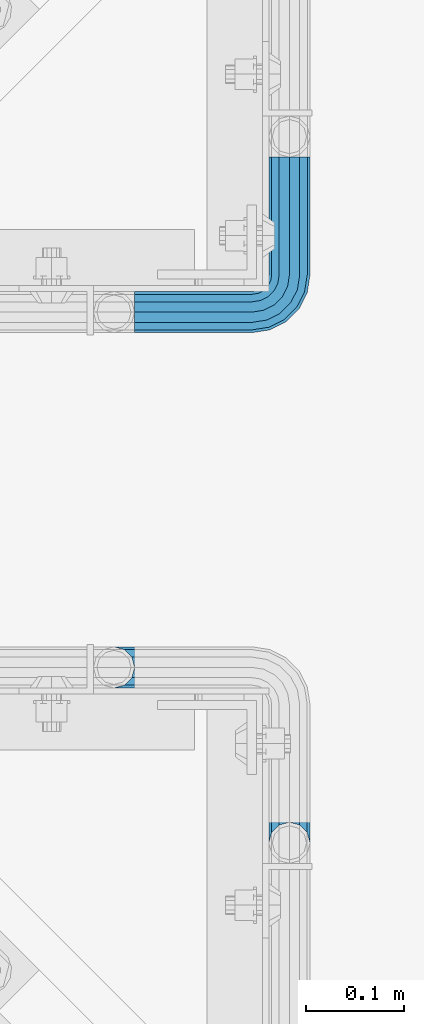
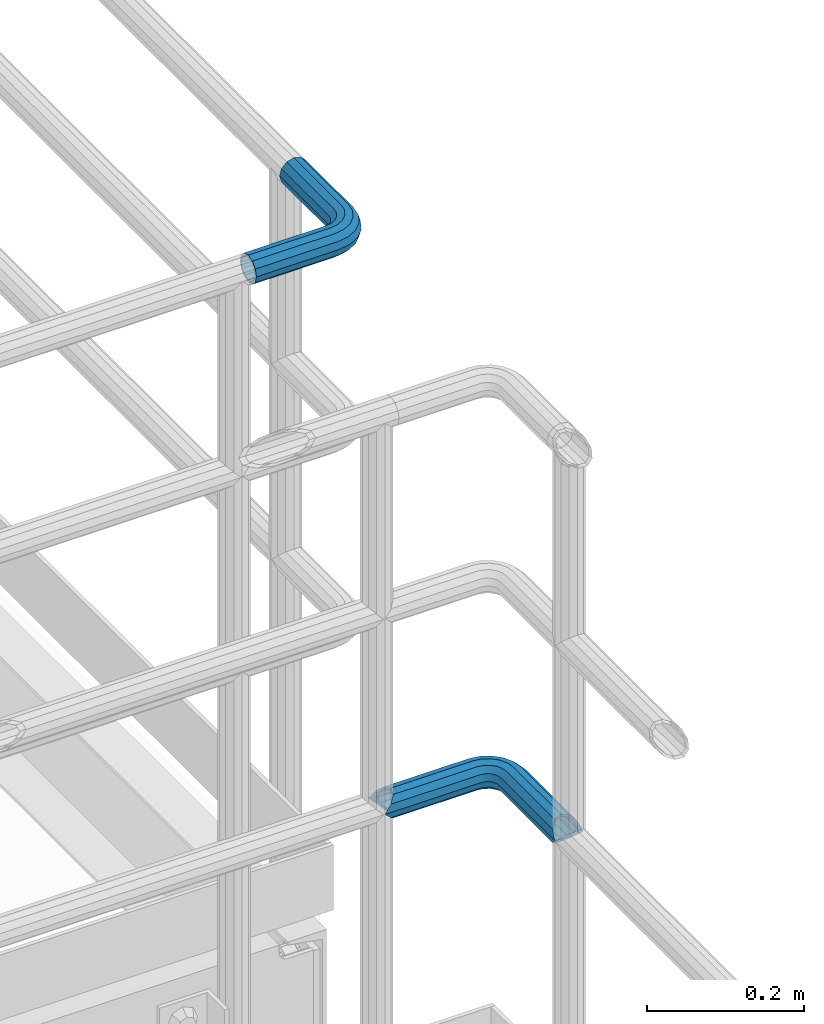
# One storey, part 1120 of 1876: 2 beams, 2 elements without a shape of their own.
"""IFC2X3 building model written with IfcOpenShell, lengths in millimetres."""

from ifc_helpers import new_model, si_unit, frame, origin_with_axes, place, context, subcontext, project, spatial, faceted_brep, material, type_object, element, aggregate, save


model = new_model("IFC2X3")

# Units and contexts
model_context = context("Model", 3, precision=1e-05, world=origin_with_axes())
body_context = subcontext(model_context, "Body", "Model", "MODEL_VIEW")
ifc_project = project(units=[si_unit("LENGTHUNIT", "METRE", prefix="MILLI"), si_unit("AREAUNIT", "SQUARE_METRE"), si_unit("VOLUMEUNIT", "CUBIC_METRE"), si_unit("MASSUNIT", "GRAM", prefix="KILO"), si_unit("TIMEUNIT", "SECOND"), si_unit("PLANEANGLEUNIT", "RADIAN"), si_unit("SOLIDANGLEUNIT", "STERADIAN"), si_unit("THERMODYNAMICTEMPERATUREUNIT", "DEGREE_CELSIUS"), si_unit("LUMINOUSINTENSITYUNIT", "LUMEN")], contexts=[model_context])

# Site, building, storey
site_placement = place(None, origin_with_axes())
site = spatial("IfcSite", under=ifc_project, at=site_placement, CompositionType="ELEMENT")
building_placement = place(site_placement, origin_with_axes())
building = spatial("IfcBuilding", under=site, at=building_placement, Name="Undefined", CompositionType="ELEMENT")
storey_placement = place(building_placement, origin_with_axes())
storey = spatial("IfcBuildingStorey", under=building, at=storey_placement, Name="Undefined", CompositionType="ELEMENT", Elevation=0.0)

# Assembly, beam
assembly_1_placement = place(storey_placement, origin_with_axes())
assembly_1 = element("IfcElementAssembly", 1, at=assembly_1_placement, inside=storey, Name="HANDRAIL", AssemblyPlace="NOTDEFINED", PredefinedType="RIGID_FRAME")
ifc_material = material()
beam_type = type_object("IfcBeamType", Name="PIPE1-1/4STD", PredefinedType="NOTDEFINED")
beam_1_placement = place(assembly_1_placement, frame((6866.33912093762, -11381.1963554687, 9090.025), z_axis=(0.0, 0.0, -1.0), x_axis=(1.0, 0.0, 0.0)))
beam_1 = element("IfcBeam", 2, at=beam_1_placement, type_object=beam_type, material=ifc_material, Name="HANDRAIL", ObjectType="PIPE1-1/4STD", context=body_context, shape_type="Brep", body=[
    faceted_brep([(9.09494701772928e-13, -21.0820000000003, 0.0), (0.0, -18.2575475625836, -10.5409999999993), (120.6947555542, -18.2575475625854, -10.5409999999956), (120.694755554199, -21.0820000000022, 3.63797880709171e-12), (0.0, -10.5410000000002, -18.2575475625836), (120.6947555542, -10.5410000000029, -18.2575475625799), (-4.28826751885936e-09, 0.0, -21.0820000000003), (120.694755554201, -3.63797880709171e-12, -21.0819999999967), (0.0, 10.5410000000002, -18.2575475625836), (120.694755554201, 10.5409999999974, -18.2575475625799), (0.0, 18.2575475625836, -10.5409999999993), (120.694755554201, 18.2575475625799, -10.5409999999956), (9.09494701772928e-13, 21.0820000000003, 0.0), (120.694755554201, 21.0819999999967, 3.63797880709171e-12), (0.0, 18.2575475625836, 10.5409999999993), (120.6947555542, 18.2575475625799, 10.5410000000047), (0.0, 10.5410000000002, 18.2575475625836), (120.6947555542, 10.5409999999974, 18.2575475625872), (0.0, 0.0, 21.0820000000003), (120.694755554199, -3.63797880709171e-12, 21.082000000004), (0.0, -10.5410000000002, 18.2575475625836), (120.694755554199, -10.5410000000029, 18.2575475625872), (0.0, -18.2575475625836, 10.5409999999993), (120.694755554199, -18.2575475625872, 10.5410000000047), (0.0, -17.5259999999998, 0.0), (0.0, -15.1779612267264, 8.76300000000083), (120.694755554199, -15.1779612267292, 8.76300000000447), (120.6947555542, -17.5260000000035, 3.63797880709171e-12), (0.0, -8.76299999999992, 15.1779612267255), (120.694755554199, -8.76300000000265, 15.177961226731), (0.0, 0.0, 17.5259999999998), (120.694755554199, -3.63797880709171e-12, 17.5260000000035), (0.0, 8.76299999999992, 15.1779612267255), (120.6947555542, 8.76299999999719, 15.177961226731), (0.0, 15.1779612267264, 8.76300000000083), (120.6947555542, 15.1779612267237, 8.76300000000447), (0.0, 17.5259999999998, 0.0), (120.694755554201, 17.525999999998, 3.63797880709171e-12), (0.0, 15.1779612267264, -8.76300000000083), (120.694755554201, 15.1779612267237, -8.76299999999537), (0.0, 8.76299999999992, -15.1779612267255), (120.694755554201, 8.76299999999719, -15.1779612267219), (0.0, 0.0, -17.5259999999998), (120.694755554201, -3.63797880709171e-12, -17.5259999999962), (0.0, -8.76299999999992, -15.1779612267255), (120.6947555542, -8.76300000000265, -15.1779612267219), (0.0, -15.1779612267264, -8.76300000000083), (120.6947555542, -15.1779612267292, -8.76299999999537), (125.95360629295, -21.9149201310101, 3.63797880709171e-12), (126.826410095915, -19.2287062354389, 10.5410000000047), (129.210954430656, -11.8898333927427, 18.2575475625872), (132.468302568363, -1.86474665447531, 21.082000000004), (135.725650706068, 8.16034008379211, 18.257547562589), (138.11019504081, 15.4992129264883, 10.5410000000047), (138.982998843776, 18.1854268220577, 5.45696821063757e-12), (138.110195040815, 15.4992129264865, -10.5409999999956), (135.72565070607, 8.16034008379211, -18.2575475625781), (132.468302568363, -1.86474665447531, -21.0819999999949), (129.210954430657, -11.8898333927427, -18.2575475625799), (126.826410095916, -19.2287062354389, -10.5409999999956), (137.884134411778, 14.8034698501124, 5.45696821063757e-12), (137.158550527389, 12.5703522742751, 8.76300000000447), (135.17621849007, 6.46936159781944, 15.177961226731), (132.468302568363, -1.86474665447531, 17.5260000000053), (129.760386646654, -10.1988549067701, 15.177961226731), (127.77805460934, -16.2998455832294, 8.76300000000447), (127.052470724947, -18.5329631590648, 3.63797880709171e-12), (127.77805460934, -16.2998455832294, -8.76299999999537), (129.760386646655, -10.1988549067701, -15.1779612267219), (132.468302568363, -1.86474665447531, -17.5259999999962), (135.176218490071, 6.46936159781762, -15.1779612267219), (137.158550527385, 12.570352274277, -8.76299999999537), (149.285217114073, 1.25139591480183, 18.257547562589), (153.820889969974, 7.49421403083397, 10.5410000000047), (143.089372769657, -7.27645222290448, 21.082000000004), (136.893528425241, -15.804300360609, 18.2575475625872), (132.35785556934, -22.0471184766411, 10.5410000000047), (130.697684080826, -24.3321484983135, 3.63797880709171e-12), (132.357855569341, -22.0471184766411, -10.5409999999956), (136.893528425242, -15.804300360609, -18.2575475625781), (143.089372769658, -7.27645222290266, -21.0819999999949), (149.285217114074, 1.25139591480183, -18.2575475625781), (153.820889969975, 7.49421403083397, -10.5409999999956), (155.481061458489, 9.77924405250815, 5.45696821063757e-12), (152.010754538596, 5.00277634947997, -8.76299999999537), (153.390897101337, 6.90237962051106, 5.45696821063757e-12), (148.240134935498, -0.187036301196713, -15.1779612267219), (143.089372769658, -7.27645222290266, -17.5259999999944), (137.938610603818, -14.3658681446104, -15.1779612267219), (134.16799100072, -19.5556807952871, -8.76299999999537), (132.787848437978, -21.4552840663182, 3.63797880709171e-12), (134.167991000719, -19.5556807952871, 8.76300000000447), (137.938610603817, -14.3658681446104, 15.177961226731), (143.089372769657, -7.27645222290448, 17.5260000000053), (148.240134935497, -0.187036301196713, 15.177961226731), (152.010754538595, 5.00277634947997, 8.76300000000447), (160.046149943129, -9.50953691425639, 18.257547562589), (166.288968059162, -4.97386405835641, 10.5410000000047), (151.518301805423, -15.705381258671, 21.082000000004), (142.990453667717, -21.9012256030855, 18.257547562589), (136.747635551684, -26.4368984589855, 10.5410000000047), (134.46260553001, -28.0970699475001, 3.63797880709171e-12), (136.747635551685, -26.4368984589855, -10.5409999999956), (142.990453667717, -21.9012256030855, -18.2575475625781), (151.518301805424, -15.705381258671, -21.0819999999949), (160.04614994313, -9.50953691425639, -18.2575475625781), (166.28896805916, -4.97386405835277, -10.5409999999956), (168.573998080837, -3.31369256984181, 5.45696821063757e-12), (163.797530377809, -6.78399948973492, -8.76299999999537), (165.697133648839, -5.40385692699419, 5.45696821063757e-12), (158.607717727132, -10.5546190928326, -15.1779612267219), (151.518301805424, -15.705381258671, -17.5259999999944), (144.428885883715, -20.8561434245094, -15.1779612267219), (139.239073233038, -24.626763027607, -8.76299999999537), (137.339469962008, -26.0069055903477, 3.63797880709171e-12), (139.239073233038, -24.626763027607, 8.76300000000447), (144.428885883715, -20.8561434245094, 15.177961226731), (151.518301805423, -15.705381258671, 17.5260000000053), (158.607717727131, -10.5546190928326, 15.177961226731), (163.797530377807, -6.78399948973129, 8.76300000000447), (166.955094112112, -23.069103322252, 18.257547562589), (174.29396695481, -20.6845589875102, 10.5410000000047), (156.930007373846, -26.3264514599596, 21.082000000004), (146.904920635579, -29.5837995976653, 18.2575475625872), (139.566047792883, -31.9683439324072, 10.5410000000047), (136.879833897313, -32.8411477353729, 3.63797880709171e-12), (139.566047792883, -31.9683439324072, -10.5409999999956), (146.904920635579, -29.5837995976653, -18.2575475625781), (156.930007373847, -26.3264514599578, -21.0819999999949), (166.955094112113, -23.0691033222502, -18.2575475625781), (174.29396695481, -20.6845589875102, -10.5409999999956), (176.98018085038, -19.8117551845444, 5.45696821063757e-12), (171.365106302599, -21.6362035009352, -8.76299999999537), (173.598223878435, -20.9106196165412, 5.45696821063757e-12), (165.264115626141, -23.6185355382495, -15.1779612267219), (156.930007373847, -26.3264514599578, -17.5259999999944), (148.595899121552, -29.034367381666, -15.1779612267219), (142.494908445094, -31.0166994189822, -8.76299999999537), (140.261790869258, -31.7422833033743, 3.63797880709171e-12), (142.494908445094, -31.0166994189822, 8.76300000000447), (148.595899121552, -29.034367381666, 15.177961226731), (156.930007373846, -26.3264514599578, 17.5260000000053), (165.264115626141, -23.6185355382495, 15.177961226731), (171.365106302599, -21.6362035009352, 8.76300000000447), (148.25375402832, -38.0999984741229, -18.2575475625799), (140.537206465737, -38.0999984741229, -10.5409999999956), (158.79475402832, -38.0999984741229, -21.0819999999949), (169.33575402832, -38.0999984741229, -18.2575475625781), (177.052301590904, -38.0999984741247, -10.5409999999956), (179.87675402832, -38.0999984741247, 5.45696821063757e-12), (177.052301590903, -38.0999984741247, 10.5410000000047), (169.33575402832, -38.0999984741247, 18.257547562589), (158.794754028319, -38.0999984741247, 21.082000000004), (148.253754028319, -38.0999984741247, 18.2575475625872), (140.537206465737, -38.0999984741247, 10.5410000000047), (137.71275402832, -38.0999984741247, 5.45696821063757e-12), (173.972715255046, -38.0999984741247, -8.76299999999537), (176.32075402832, -38.0999984741247, 5.45696821063757e-12), (167.55775402832, -38.0999984741229, -15.1779612267219), (158.79475402832, -38.0999984741229, -17.5259999999962), (150.03175402832, -38.0999984741229, -15.1779612267219), (143.616792801594, -38.0999984741229, -8.76299999999537), (141.26875402832, -38.0999984741247, 5.45696821063757e-12), (143.616792801594, -38.0999984741247, 8.76300000000447), (150.031754028319, -38.0999984741247, 15.177961226731), (158.794754028319, -38.0999984741247, 17.5260000000053), (167.557754028319, -38.0999984741247, 15.177961226731), (173.972715255046, -38.0999984741247, 8.76300000000447), (140.537206465737, -158.797622680664, -10.5409999999974), (137.71275402832, -158.797622680664, 1.81898940354586e-12), (148.25375402832, -158.797622680664, -18.2575475625817), (158.79475402832, -158.797622680664, -21.0819999999985), (169.33575402832, -158.797622680664, -18.2575475625817), (177.052301590904, -158.797622680664, -10.5409999999974), (179.876754028321, -158.797622680664, 1.81898940354586e-12), (177.052301590904, -158.797622680664, 10.5410000000011), (169.33575402832, -158.797622680664, 18.2575475625854), (158.79475402832, -158.797622680664, 21.0820000000022), (148.25375402832, -158.797622680664, 18.2575475625854), (140.537206465737, -158.797622680664, 10.5410000000011), (143.616792801594, -158.797622680664, 8.76300000000265), (141.26875402832, -158.797622680664, 1.81898940354586e-12), (150.03175402832, -158.797622680664, 15.1779612267273), (158.79475402832, -158.797622680664, 17.5260000000017), (167.55775402832, -158.797622680664, 15.1779612267273), (173.972715255047, -158.797622680664, 8.76300000000265), (176.32075402832, -158.797622680664, 1.81898940354586e-12), (173.972715255047, -158.797622680664, -8.76299999999901), (167.55775402832, -158.797622680664, -15.1779612267237), (158.79475402832, -158.797622680664, -17.525999999998), (150.03175402832, -158.797622680664, -15.1779612267237), (143.616792801594, -158.797622680664, -8.76299999999901)], [[[0, 1, 2, 3]], [[1, 4, 5, 2]], [[4, 6, 7, 5]], [[6, 8, 9, 7]], [[8, 10, 11, 9]], [[10, 12, 13, 11]], [[12, 14, 15, 13]], [[14, 16, 17, 15]], [[16, 18, 19, 17]], [[18, 20, 21, 19]], [[20, 22, 23, 21]], [[22, 0, 3, 23]], [[24, 25, 26, 27]], [[25, 28, 29, 26]], [[28, 30, 31, 29]], [[30, 32, 33, 31]], [[32, 34, 35, 33]], [[34, 36, 37, 35]], [[36, 38, 39, 37]], [[38, 40, 41, 39]], [[40, 42, 43, 41]], [[42, 44, 45, 43]], [[44, 46, 47, 45]], [[46, 24, 27, 47]], [[22, 20, 18, 16, 14, 12, 10, 8, 6, 4, 1, 0], [46, 44, 42, 40, 38, 36, 34, 32, 30, 28, 25, 24]], [[23, 3, 48, 49]], [[21, 23, 49, 50]], [[19, 21, 50, 51]], [[17, 19, 51, 52]], [[15, 17, 52, 53]], [[13, 15, 53, 54]], [[11, 13, 54, 55]], [[9, 11, 55, 56]], [[7, 9, 56, 57]], [[5, 7, 57, 58]], [[2, 5, 58, 59]], [[3, 2, 59, 48]], [[35, 37, 60, 61]], [[33, 35, 61, 62]], [[31, 33, 62, 63]], [[29, 31, 63, 64]], [[26, 29, 64, 65]], [[27, 26, 65, 66]], [[47, 27, 66, 67]], [[45, 47, 67, 68]], [[43, 45, 68, 69]], [[41, 43, 69, 70]], [[39, 41, 70, 71]], [[37, 39, 71, 60]], [[52, 72, 73, 53]], [[51, 74, 72, 52]], [[50, 75, 74, 51]], [[49, 76, 75, 50]], [[48, 77, 76, 49]], [[59, 78, 77, 48]], [[58, 79, 78, 59]], [[57, 80, 79, 58]], [[56, 81, 80, 57]], [[55, 82, 81, 56]], [[54, 83, 82, 55]], [[53, 73, 83, 54]], [[71, 84, 85, 60]], [[70, 86, 84, 71]], [[69, 87, 86, 70]], [[68, 88, 87, 69]], [[67, 89, 88, 68]], [[66, 90, 89, 67]], [[65, 91, 90, 66]], [[64, 92, 91, 65]], [[63, 93, 92, 64]], [[62, 94, 93, 63]], [[61, 95, 94, 62]], [[60, 85, 95, 61]], [[72, 96, 97, 73]], [[74, 98, 96, 72]], [[75, 99, 98, 74]], [[76, 100, 99, 75]], [[77, 101, 100, 76]], [[78, 102, 101, 77]], [[79, 103, 102, 78]], [[80, 104, 103, 79]], [[81, 105, 104, 80]], [[82, 106, 105, 81]], [[83, 107, 106, 82]], [[73, 97, 107, 83]], [[84, 108, 109, 85]], [[86, 110, 108, 84]], [[87, 111, 110, 86]], [[88, 112, 111, 87]], [[89, 113, 112, 88]], [[90, 114, 113, 89]], [[91, 115, 114, 90]], [[92, 116, 115, 91]], [[93, 117, 116, 92]], [[94, 118, 117, 93]], [[95, 119, 118, 94]], [[85, 109, 119, 95]], [[96, 120, 121, 97]], [[98, 122, 120, 96]], [[99, 123, 122, 98]], [[100, 124, 123, 99]], [[101, 125, 124, 100]], [[102, 126, 125, 101]], [[103, 127, 126, 102]], [[104, 128, 127, 103]], [[105, 129, 128, 104]], [[106, 130, 129, 105]], [[107, 131, 130, 106]], [[97, 121, 131, 107]], [[108, 132, 133, 109]], [[110, 134, 132, 108]], [[111, 135, 134, 110]], [[112, 136, 135, 111]], [[113, 137, 136, 112]], [[114, 138, 137, 113]], [[115, 139, 138, 114]], [[116, 140, 139, 115]], [[117, 141, 140, 116]], [[118, 142, 141, 117]], [[119, 143, 142, 118]], [[109, 133, 143, 119]], [[127, 144, 145, 126]], [[128, 146, 144, 127]], [[129, 147, 146, 128]], [[130, 148, 147, 129]], [[131, 149, 148, 130]], [[121, 150, 149, 131]], [[120, 151, 150, 121]], [[122, 152, 151, 120]], [[123, 153, 152, 122]], [[124, 154, 153, 123]], [[125, 155, 154, 124]], [[126, 145, 155, 125]], [[132, 156, 157, 133]], [[134, 158, 156, 132]], [[135, 159, 158, 134]], [[136, 160, 159, 135]], [[137, 161, 160, 136]], [[138, 162, 161, 137]], [[139, 163, 162, 138]], [[140, 164, 163, 139]], [[141, 165, 164, 140]], [[142, 166, 165, 141]], [[143, 167, 166, 142]], [[133, 157, 167, 143]], [[155, 145, 168, 169]], [[145, 144, 170, 168]], [[144, 146, 171, 170]], [[146, 147, 172, 171]], [[147, 148, 173, 172]], [[148, 149, 174, 173]], [[149, 150, 175, 174]], [[150, 151, 176, 175]], [[151, 152, 177, 176]], [[152, 153, 178, 177]], [[153, 154, 179, 178]], [[154, 155, 169, 179]], [[162, 163, 180, 181]], [[163, 164, 182, 180]], [[164, 165, 183, 182]], [[165, 166, 184, 183]], [[166, 167, 185, 184]], [[167, 157, 186, 185]], [[157, 156, 187, 186]], [[156, 158, 188, 187]], [[158, 159, 189, 188]], [[159, 160, 190, 189]], [[160, 161, 191, 190]], [[161, 162, 181, 191]], [[170, 171, 172, 173, 174, 175, 176, 177, 178, 179, 169, 168], [182, 183, 184, 185, 186, 187, 188, 189, 190, 191, 181, 180]]]),
])
aggregate(assembly_1, [beam_1])

assembly_2_placement = place(storey_placement, origin_with_axes())
assembly_2 = element("IfcElementAssembly", 3, at=assembly_2_placement, inside=storey, Name="HANDRAIL", AssemblyPlace="NOTDEFINED", PredefinedType="RIGID_FRAME")
beam_2_placement = place(assembly_2_placement, frame((6845.30143150122, -11745.4324531237, 8480.425), z_axis=(0.0, 0.0, -1.0), x_axis=(1.0, 0.0, 0.0)))
beam_2 = element("IfcBeam", 4, at=beam_2_placement, type_object=beam_type, material=ifc_material, Name="HANDRAIL", ObjectType="PIPE1-1/4STD", context=body_context, shape_type="Brep", body=[
    faceted_brep([(9.09494701772928e-13, 21.0820000000003, 0.0), (10.5409999957128, 18.2575475579433, -10.5409999999993), (10.5409999999983, 18.2575475625836, 10.5410000000011), (10.5409999999983, -18.2575475625836, 10.5410000000011), (10.5409999957128, -18.2575475672238, -10.5409999999993), (9.09494701772928e-13, -21.0820000000003, 0.0), (18.2575475625817, -10.5410000000011, 18.2575475625836), (18.2575475625817, -10.5409999999974, 13.3999612267289), (13.6205863358537, -15.1779612267255, 8.76300000000083), (11.2725475625793, -17.5259999999998, 0.0), (13.6205863358537, -15.1779612267255, -8.76299999999901), (18.2575475625817, -10.5409999999974, -13.3999612267271), (18.2575475625817, -10.5410000000011, -18.2575475625836), (21.0819999999985, 0.0, -17.5259999999998), (21.0819999999985, 0.0, -21.0819999999985), (18.7339612267233, -8.76300000000083, -15.1779612267255), (18.7339612267251, 8.76299999999901, -15.1779612267255), (18.2575475625817, 10.5410000000011, -13.3999612267235), (18.2575475625817, 10.5409999999993, -18.2575475625836), (13.6205863358573, 15.1779612267255, -8.76299999999901), (11.2725475625839, 17.5259999999998, 0.0), (13.6205863358573, 15.1779612267255, 8.76300000000083), (18.2575475625817, 10.5410000000011, 13.3999612267253), (18.2575475625817, 10.5409999999993, 18.2575475625836), (18.7339612267251, 8.76299999999901, 15.1779612267273), (21.0819999999985, 1.81898940354586e-12, 17.5259999999998), (21.0819999999985, 1.81898940354586e-12, 21.0820000000003), (18.7339612267233, -8.76300000000083, 15.1779612267273), (141.729133605958, -8.76300000000265, 15.177961226731), (141.729133605958, -3.63797880709171e-12, 17.5260000000035), (153.502680620123, 1.86474665447895, 17.5259999999998), (156.210596541831, -6.46936159781399, 15.1779612267255), (141.729133605958, -15.1779612267292, 8.76300000000447), (158.192928579147, -12.5703522742733, 8.76300000000083), (141.729133605958, -17.5260000000035, 3.63797880709171e-12), (158.91851246354, -14.8034698501087, 0.0), (141.729133605959, -15.1779612267292, -8.76299999999537), (158.192928579147, -12.5703522742733, -8.76300000000083), (141.729133605959, -8.76300000000265, -15.1779612267219), (156.210596541831, -6.46936159781399, -15.1779612267255), (141.729133605959, -3.63797880709171e-12, -17.5259999999962), (153.502680620123, 1.86474665447895, -17.5259999999998), (141.72913360596, 8.76299999999719, -15.1779612267219), (150.794764698415, 10.1988549067737, -15.1779612267255), (141.72913360596, 15.1779612267237, -8.76299999999537), (148.8124326611, 16.2998455832312, -8.76300000000083), (141.729133605959, 17.525999999998, 3.63797880709171e-12), (148.086848776707, 18.5329631590685, 0.0), (141.729133605959, 15.1779612267237, 8.76300000000447), (148.8124326611, 16.2998455832312, 8.76300000000083), (141.729133605959, 8.76299999999719, 15.177961226731), (150.794764698415, 10.1988549067737, 15.1779612267255), (171.066132080078, 38.0999984741266, -15.1779612267255), (179.829132080078, 38.0999984741266, -17.5259999999998), (179.829132080079, 158.749951173106, -17.5259999999998), (171.066132080079, 161.097991264016, -15.1779612267255), (198.086679642661, 38.0999984741266, -10.5409999999993), (190.370132080077, 38.0999984741266, -18.2575475625836), (190.370132080079, 161.574403610522, -18.2575475625836), (198.086679642663, 169.290951173107, -10.5409999999993), (200.911132080079, 38.0999984741266, 0.0), (200.911136997563, 179.831951173106, 0.0), (198.086679642663, 169.290951173107, 10.5409999999993), (198.086679642661, 38.0999984741266, 10.5409999999993), (190.370132080077, 38.0999984741266, 18.2575475625836), (190.370132080079, 161.574403610522, 18.2575475625836), (179.829132080078, 38.0999984741266, 21.0820000000003), (179.829132080079, 158.749951173106, 21.0820000000003), (141.729133605959, 18.2575475625799, 10.5410000000047), (141.729133605959, 21.0819999999967, 3.63797880709171e-12), (141.72913360596, 18.2575475625799, -10.5409999999956), (141.72913360596, 10.5409999999974, -18.2575475625799), (141.729133605959, -3.63797880709171e-12, -21.0819999999949), (141.729133605959, -10.5410000000029, -18.2575475625799), (141.729133605959, -18.2575475625872, -10.5409999999956), (141.729133605958, -21.0820000000022, 3.63797880709171e-12), (141.729133605958, -18.2575475625872, 10.5410000000047), (141.729133605958, -10.5410000000029, 18.2575475625872), (141.729133605958, -3.63797880709171e-12, 21.082000000004), (141.729133605959, 10.5409999999974, 18.2575475625872), (150.245332482416, 11.8898333927464, 18.2575475625836), (147.860788147675, 19.2287062354426, 10.5409999999993), (146.987984344709, 21.9149201310138, 0.0), (147.860788147675, 19.2287062354426, -10.5409999999993), (150.245332482416, 11.8898333927464, -18.2575475625836), (153.502680620123, 1.86474665447895, -21.0820000000003), (156.760028757831, -8.16034008378665, -18.2575475625836), (159.144573092572, -15.4992129264829, -10.5409999999993), (160.017376895537, -18.1854268220541, 0.0), (159.144573092572, -15.4992129264829, 10.5409999999993), (156.760028757831, -8.16034008378665, 18.2575475625836), (153.502680620123, 1.86474665447895, 21.0820000000003), (164.123750821417, 7.27645222290812, 21.0820000000003), (157.927906477001, 15.8043003606126, 18.2575475625836), (170.319595165834, -1.25139591479638, 18.2575475625836), (174.855268021735, -7.49421403082852, 10.5409999999993), (176.51543951025, -9.77924405250269, 0.0), (174.855268021735, -7.49421403082852, -10.5409999999993), (170.319595165834, -1.25139591479638, -18.2575475625836), (164.123750821417, 7.27645222290812, -21.0820000000003), (157.927906477001, 15.8043003606126, -18.2575475625836), (153.3922336211, 22.0471184766448, -10.5409999999993), (151.732062132584, 24.3321484983171, 0.0), (153.3922336211, 22.0471184766448, 10.5409999999993), (164.024831719472, 21.9012256030837, 18.2575475625836), (157.782013603441, 26.4368984589855, 10.5409999999993), (172.552679857177, 15.7053812586691, 21.0820000000003), (181.080527994883, 9.50953691425275, 18.2575475625836), (187.323346110915, 4.97386405835096, 10.5409999999993), (189.608376132588, 3.31369256983635, 0.0), (187.323346110915, 4.97386405835096, -10.5409999999993), (181.080527994883, 9.50953691425275, -18.2575475625836), (172.552679857177, 15.7053812586691, -21.0820000000003), (164.024831719472, 21.9012256030837, -18.2575475625836), (157.782013603441, 26.4368984589855, -10.5409999999993), (155.496983581766, 28.0970699475001, 0.0), (160.600425844642, 31.9683439324108, 10.5409999999993), (157.914211949071, 32.8411477353766, 0.0), (167.939298687338, 29.583799597669, 18.2575475625836), (177.964385425605, 26.3264514599632, 21.0820000000003), (187.989472163872, 23.0691033222574, 18.2575475625836), (195.328345006568, 20.6845589875156, 10.5409999999993), (198.014558902139, 19.8117551845498, 0.0), (195.328345006568, 20.6845589875156, -10.5409999999993), (187.989472163872, 23.0691033222574, -18.2575475625836), (177.964385425605, 26.3264514599632, -21.0820000000003), (167.939298687338, 29.583799597669, -18.2575475625836), (160.600425844642, 31.9683439324108, -10.5409999999993), (158.747132080079, 38.0999984741266, 0.0), (161.571584517495, 38.0999984741266, -10.5409999999993), (161.571584517495, 38.0999984741266, 10.5409999999993), (169.288132080078, 38.0999984741266, 18.2575475625836), (179.829132080078, 38.0999984741266, -21.0820000000003), (169.288132080078, 38.0999984741266, -18.2575475625836), (161.571584517495, 169.290951173107, -10.5409999999993), (169.288132080079, 161.574403610522, -18.2575475625836), (179.829132080079, 158.749951173106, -21.0820000000003), (190.370136997562, 161.574403610522, -13.399956309242), (188.592132080079, 161.097988628744, -15.1779612267255), (188.592132080077, 38.0999984741266, -15.1779612267255), (195.007093306804, 38.0999984741266, -8.76300000000083), (195.007093306805, 166.211359919766, -8.76300000000083), (197.355132080079, 38.0999984741266, 0.0), (197.355132080079, 168.55939869304, 0.0), (195.007093306804, 38.0999984741266, 8.76300000000083), (195.007093306805, 166.211359919766, 8.76300000000083), (190.370136997562, 161.574403610522, 13.399956309242), (188.592132080077, 38.0999984741266, 15.1779612267255), (188.592132080079, 161.097988628744, 15.1779612267255), (179.829132080079, 158.749951173106, 17.5259999999998), (179.829132080078, 38.0999984741266, 17.5259999999998), (171.066132080078, 38.0999984741266, 15.1779612267255), (171.066132080079, 161.097991264016, 15.1779612267255), (162.303132080078, 38.0999984741266, 0.0), (164.651170853352, 38.0999984741266, -8.76300000000083), (164.651170853353, 166.211369754732, -8.76300000000083), (162.303132080079, 168.559408528006, 0.0), (164.651170853352, 38.0999984741266, 8.76300000000083), (164.651170853353, 166.211369754732, 8.76300000000083), (169.288136997562, 161.574403610522, 13.3999661442085), (169.288132080079, 161.574403610522, 18.2575475625836), (161.571584517495, 169.290951173107, 10.5409999999993), (158.747132080079, 179.831954956055, 0.0), (169.288136997562, 161.574403610522, -13.3999661442085), (169.630277173311, 29.0343673816715, -15.1779612267255), (163.529286496852, 31.0166994189858, -8.76300000000083), (177.964385425605, 26.3264514599632, -17.5259999999998), (186.298493677899, 23.6185355382549, -15.1779612267255), (192.399484354358, 21.6362035009406, -8.76300000000083), (194.632601930193, 20.9106196165467, 0.0), (192.399484354358, 21.6362035009406, 8.76300000000083), (186.298493677899, 23.6185355382549, 15.1779612267255), (177.964385425605, 26.3264514599632, 17.5259999999998), (169.630277173311, 29.0343673816715, 15.1779612267255), (163.529286496852, 31.0166994189858, 8.76300000000083), (161.296168921016, 31.7422833033779, 0.0), (160.273451284794, 24.626763027607, -8.76300000000083), (158.373848013764, 26.0069055903477, 0.0), (165.46326393547, 20.8561434245075, -15.1779612267255), (172.552679857177, 15.7053812586691, -17.5259999999998), (179.642095778884, 10.5546190928289, -15.1779612267255), (184.831908429562, 6.78399948973129, -8.76300000000083), (186.731511700591, 5.40385692698874, 0.0), (184.831908429562, 6.78399948973129, 8.76300000000083), (179.642095778884, 10.5546190928289, 15.1779612267255), (172.552679857177, 15.7053812586691, 17.5259999999998), (165.46326393547, 20.8561434245075, 15.1779612267255), (160.273451284794, 24.626763027607, 8.76300000000083), (153.822226489737, 21.45528406632, 0.0), (155.202369052478, 19.5556807952908, 8.76300000000083), (155.202369052478, 19.5556807952908, -8.76300000000083), (158.972988655577, 14.3658681446141, -15.1779612267255), (164.123750821417, 7.27645222290812, -17.5259999999998), (169.274512987257, 0.187036301200351, -15.1779612267255), (173.045132590356, -5.00277634947633, -8.76300000000083), (174.425275153098, -6.9023796205056, 0.0), (173.045132590356, -5.00277634947633, 8.76300000000083), (169.274512987257, 0.18703630120217, 15.1779612267255), (164.123750821417, 7.27645222290812, 17.5259999999998), (158.972988655577, 14.3658681446141, 15.1779612267255)], [[[0, 1, 2]], [[3, 4, 5]], [[6, 7, 8, 9, 10, 11, 12, 4, 3]], [[13, 14, 12, 11, 15]], [[16, 17, 18, 14, 13]], [[2, 1, 18, 17, 19, 20, 21, 22, 23]], [[23, 22, 24, 25, 26]], [[26, 25, 27, 7, 6]], [[28, 29, 30, 31]], [[32, 28, 31, 33]], [[34, 32, 33, 35]], [[36, 34, 35, 37]], [[38, 36, 37, 39]], [[40, 38, 39, 41]], [[42, 40, 41, 43]], [[44, 42, 43, 45]], [[46, 44, 45, 47]], [[48, 46, 47, 49]], [[50, 48, 49, 51]], [[52, 53, 54, 55]], [[56, 57, 58, 59]], [[60, 56, 59, 61]], [[61, 59, 62]], [[63, 60, 61, 62]], [[64, 63, 62, 65]], [[66, 64, 65, 67]], [[68, 69, 0, 2]], [[69, 70, 1, 0]], [[70, 71, 18, 1]], [[71, 72, 14, 18]], [[72, 73, 12, 14]], [[73, 74, 4, 12]], [[74, 75, 5, 4]], [[75, 76, 3, 5]], [[76, 77, 6, 3]], [[77, 78, 26, 6]], [[78, 79, 23, 26]], [[79, 68, 2, 23]], [[68, 79, 80, 81]], [[69, 68, 81, 82]], [[70, 69, 82, 83]], [[71, 70, 83, 84]], [[72, 71, 84, 85]], [[73, 72, 85, 86]], [[74, 73, 86, 87]], [[75, 74, 87, 88]], [[76, 75, 88, 89]], [[77, 76, 89, 90]], [[78, 77, 90, 91]], [[79, 78, 91, 80]], [[91, 92, 93, 80]], [[90, 94, 92, 91]], [[89, 95, 94, 90]], [[88, 96, 95, 89]], [[87, 97, 96, 88]], [[86, 98, 97, 87]], [[85, 99, 98, 86]], [[84, 100, 99, 85]], [[83, 101, 100, 84]], [[82, 102, 101, 83]], [[81, 103, 102, 82]], [[80, 93, 103, 81]], [[93, 104, 105, 103]], [[92, 106, 104, 93]], [[94, 107, 106, 92]], [[95, 108, 107, 94]], [[96, 109, 108, 95]], [[97, 110, 109, 96]], [[98, 111, 110, 97]], [[99, 112, 111, 98]], [[100, 113, 112, 99]], [[101, 114, 113, 100]], [[102, 115, 114, 101]], [[103, 105, 115, 102]], [[105, 116, 117, 115]], [[104, 118, 116, 105]], [[106, 119, 118, 104]], [[107, 120, 119, 106]], [[108, 121, 120, 107]], [[109, 122, 121, 108]], [[110, 123, 122, 109]], [[111, 124, 123, 110]], [[112, 125, 124, 111]], [[113, 126, 125, 112]], [[114, 127, 126, 113]], [[115, 117, 127, 114]], [[117, 128, 129, 127]], [[116, 130, 128, 117]], [[118, 131, 130, 116]], [[119, 66, 131, 118]], [[120, 64, 66, 119]], [[121, 63, 64, 120]], [[122, 60, 63, 121]], [[123, 56, 60, 122]], [[124, 57, 56, 123]], [[125, 132, 57, 124]], [[126, 133, 132, 125]], [[127, 129, 133, 126]], [[133, 129, 134, 135]], [[132, 133, 135, 136]], [[57, 132, 136, 58]], [[137, 58, 136, 54, 138]], [[53, 139, 138, 54]], [[138, 139, 140, 141, 137]], [[140, 142, 143, 141]], [[142, 144, 145, 143]], [[62, 59, 58, 137, 141, 143, 145, 146, 65]], [[144, 147, 148, 146, 145]], [[65, 146, 148, 149, 67]], [[147, 150, 149, 148]], [[150, 151, 152, 149]], [[153, 154, 155, 156]], [[157, 153, 156, 158]], [[151, 157, 158, 159, 152]], [[67, 149, 152, 159, 160]], [[131, 66, 67, 160]], [[130, 131, 160, 161]], [[128, 130, 161, 162]], [[129, 128, 162, 134]], [[161, 134, 162]], [[160, 159, 158, 156, 155, 163, 135, 134, 161]], [[54, 136, 135, 163, 55]], [[155, 154, 52, 55, 163]], [[164, 52, 154, 165]], [[166, 53, 52, 164]], [[167, 139, 53, 166]], [[168, 140, 139, 167]], [[169, 142, 140, 168]], [[170, 144, 142, 169]], [[171, 147, 144, 170]], [[172, 150, 147, 171]], [[173, 151, 150, 172]], [[174, 157, 151, 173]], [[175, 153, 157, 174]], [[165, 154, 153, 175]], [[176, 165, 175, 177]], [[178, 164, 165, 176]], [[179, 166, 164, 178]], [[180, 167, 166, 179]], [[181, 168, 167, 180]], [[182, 169, 168, 181]], [[183, 170, 169, 182]], [[184, 171, 170, 183]], [[185, 172, 171, 184]], [[186, 173, 172, 185]], [[187, 174, 173, 186]], [[177, 175, 174, 187]], [[188, 177, 187, 189]], [[190, 176, 177, 188]], [[191, 178, 176, 190]], [[192, 179, 178, 191]], [[193, 180, 179, 192]], [[194, 181, 180, 193]], [[195, 182, 181, 194]], [[196, 183, 182, 195]], [[197, 184, 183, 196]], [[198, 185, 184, 197]], [[199, 186, 185, 198]], [[189, 187, 186, 199]], [[49, 189, 199, 51]], [[47, 188, 189, 49]], [[45, 190, 188, 47]], [[43, 191, 190, 45]], [[41, 192, 191, 43]], [[39, 193, 192, 41]], [[37, 194, 193, 39]], [[35, 195, 194, 37]], [[33, 196, 195, 35]], [[31, 197, 196, 33]], [[30, 198, 197, 31]], [[51, 199, 198, 30]], [[29, 50, 51, 30]], [[50, 29, 25, 24]], [[21, 48, 50, 24, 22]], [[46, 48, 21, 20]], [[44, 46, 20, 19]], [[42, 44, 19, 17, 16]], [[40, 42, 16, 13]], [[38, 40, 13, 15]], [[10, 36, 38, 15, 11]], [[34, 36, 10, 9]], [[32, 34, 9, 8]], [[28, 32, 8, 7, 27]], [[29, 28, 27, 25]]]),
])
aggregate(assembly_2, [beam_2])

save(model, "model.ifc")
